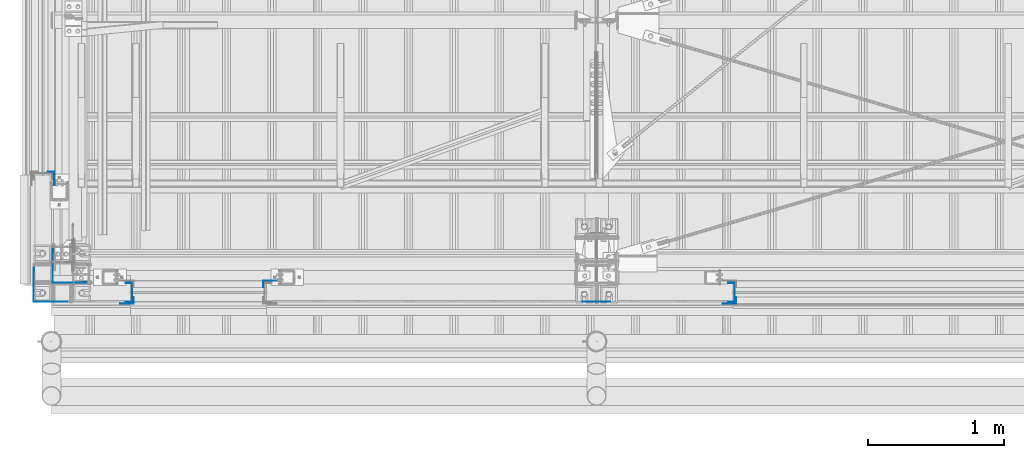
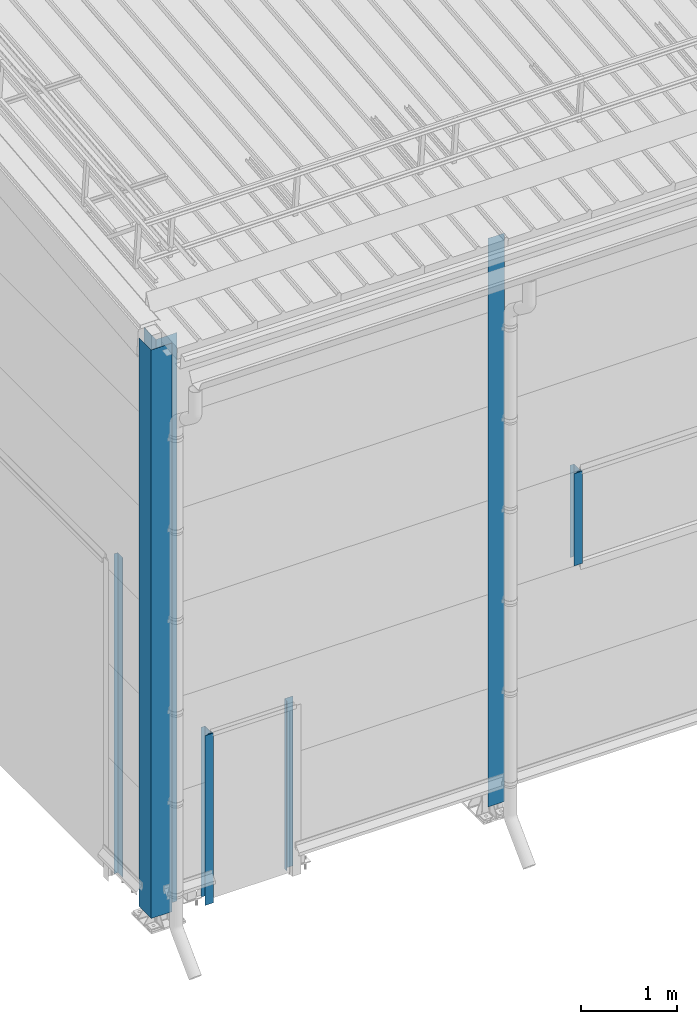
# One storey, part 1 of 709: 9 columns, 9 elements without a shape of their own.
"""IFC4 building model written with IfcOpenShell, lengths in millimetres."""

from ifc_helpers import new_model, si_unit, direction, frame, origin_with_axes, place, context, subcontext, project, spatial, line, indexed_curve, outline, extrude, material, element, aggregate, save


model = new_model("IFC4")

# Units and contexts
model_context = context("Model", 3, precision=0.2, world=origin_with_axes(), true_north=direction((0.0, 1.0)))
body_context = subcontext(model_context, "Body", "Model", "MODEL_VIEW")
ifc_project = project(units=[si_unit("LENGTHUNIT", "METRE", prefix="MILLI"), si_unit("AREAUNIT", "SQUARE_METRE"), si_unit("VOLUMEUNIT", "CUBIC_METRE"), si_unit("MASSUNIT", "GRAM", prefix="KILO"), si_unit("TIMEUNIT", "SECOND"), si_unit("PLANEANGLEUNIT", "RADIAN"), si_unit("SOLIDANGLEUNIT", "STERADIAN"), si_unit("THERMODYNAMICTEMPERATUREUNIT", "DEGREE_CELSIUS"), si_unit("LUMINOUSINTENSITYUNIT", "LUMEN")], contexts=[model_context])

# Site, building, storey
site_placement = place(None, origin_with_axes())
site = spatial("IfcSite", under=ifc_project, at=site_placement, CompositionType="ELEMENT")
building_placement = place(site_placement, origin_with_axes())
building = spatial("IfcBuilding", under=site, at=building_placement, Name="Undefined", CompositionType="ELEMENT")
storey_placement = place(building_placement, origin_with_axes())
storey = spatial("IfcBuildingStorey", under=building, at=storey_placement, Name="Undefined", CompositionType="ELEMENT", Elevation=0.0)

# Assembly, column
assembly_1_placement = place(storey_placement, frame((1555.0, 1.0, -50.0), z_axis=(0.0, 1.0, 0.0), x_axis=(0.0, 0.0, 1.0)))
assembly_1 = element("IfcElementAssembly", 1, at=assembly_1_placement, inside=storey)
ifc_material = material(Name="Steel_Undefined", Category="STEEL")
column_1_placement = place(assembly_1_placement, origin_with_axes())
column_1 = element("IfcColumn", 2, at=column_1_placement, material=ifc_material, context=body_context, shape_type="SolidModel", body=[
    extrude(outline(indexed_curve([(-25.0, -1.0), (25.0, -1.0), (25.0, 99.0), (23.0, 99.0), (23.0, 1.0), (-25.0, 1.0)], segments=[line(1, 2, 3, 4, 5, 6, 1)])), frame((0.0, 0.0, 0.0), z_axis=(-1.0, 0.0, 0.0), x_axis=(0.0, 0.0, 1.0)), (0.0, 0.0, -1.0), 2150.0),
])
aggregate(assembly_1, [column_1])

assembly_2_placement = place(storey_placement, frame((570.0, -60.0, -50.0), z_axis=(0.0, 1.0, 0.0), x_axis=(0.0, 0.0, 1.0)))
assembly_2 = element("IfcElementAssembly", 3, at=assembly_2_placement, inside=storey)
column_2_placement = place(assembly_2_placement, origin_with_axes())
column_2 = element("IfcColumn", 4, at=column_2_placement, material=ifc_material, context=body_context, shape_type="SolidModel", body=[
    extrude(outline(indexed_curve([(-70.0, -25.0), (-68.0, -25.0), (-68.0, 23.0), (68.0, 23.0), (68.0, -25.0), (70.0, -25.0), (70.0, 25.0), (-70.0, 25.0)], segments=[line(1, 2, 3, 4, 5, 6, 7, 8, 1)])), frame((0.0, 0.0, 0.0), z_axis=(-1.0, 0.0, 0.0), x_axis=(0.0, 0.0, 1.0)), (0.0, 0.0, -1.0), 2150.0),
])
aggregate(assembly_2, [column_2])

assembly_3_placement = place(storey_placement, frame((605.0, -119.0, -50.0), z_axis=(0.0, -1.0, 0.0), x_axis=(0.0, 0.0, 1.0)))
assembly_3 = element("IfcElementAssembly", 5, at=assembly_3_placement, inside=storey)
column_3_placement = place(assembly_3_placement, origin_with_axes())
column_3 = element("IfcColumn", 6, at=column_3_placement, material=ifc_material, context=body_context, shape_type="SolidModel", body=[
    extrude(outline(indexed_curve([(-25.0, -1.0), (25.0, -1.0), (25.0, 99.0), (23.0, 99.0), (23.0, 1.0), (-25.0, 1.0)], segments=[line(1, 2, 3, 4, 5, 6, 1)])), frame((0.0, 0.0, 0.0), z_axis=(-1.0, 0.0, 0.0), x_axis=(0.0, 0.0, 1.0)), (0.0, 0.0, -1.0), 2150.0),
])
aggregate(assembly_3, [column_3])

assembly_4_placement = place(storey_placement, frame((4990.0, -60.0, 2700.0), z_axis=(0.0, 1.0, 0.0), x_axis=(0.0, 0.0, 1.0)))
assembly_4 = element("IfcElementAssembly", 7, at=assembly_4_placement, inside=storey)
column_4_placement = place(assembly_4_placement, origin_with_axes())
column_4 = element("IfcColumn", 8, at=column_4_placement, material=ifc_material, context=body_context, shape_type="SolidModel", body=[
    extrude(outline(indexed_curve([(-70.0, -25.0), (-68.0, -25.0), (-68.0, 23.0), (68.0, 23.0), (68.0, -25.0), (70.0, -25.0), (70.0, 25.0), (-70.0, 25.0)], segments=[line(1, 2, 3, 4, 5, 6, 7, 8, 1)])), frame((0.0, 0.0, 0.0), z_axis=(-1.0, 0.0, 0.0), x_axis=(0.0, 0.0, 1.0)), (0.0, 0.0, -1.0), 1170.0),
])
aggregate(assembly_4, [column_4])

assembly_5_placement = place(storey_placement, frame((5025.0, -119.0, 2700.0), z_axis=(0.0, -1.0, 0.0), x_axis=(0.0, 0.0, 1.0)))
assembly_5 = element("IfcElementAssembly", 9, at=assembly_5_placement, inside=storey)
column_5_placement = place(assembly_5_placement, origin_with_axes())
column_5 = element("IfcColumn", 10, at=column_5_placement, material=ifc_material, context=body_context, shape_type="SolidModel", body=[
    extrude(outline(indexed_curve([(-25.0, -1.0), (25.0, -1.0), (25.0, 99.0), (23.0, 99.0), (23.0, 1.0), (-25.0, 1.0)], segments=[line(1, 2, 3, 4, 5, 6, 1)])), frame((0.0, 0.0, 0.0), z_axis=(-1.0, 0.0, 0.0), x_axis=(0.0, 0.0, 1.0)), (0.0, 0.0, -1.0), 1170.0),
])
aggregate(assembly_5, [column_5])

assembly_6_placement = place(storey_placement, frame((-130.0, -130.0, 0.0), z_axis=(0.0, 1.0, 0.0), x_axis=(0.0, 0.0, 1.0)))
assembly_6 = element("IfcElementAssembly", 11, at=assembly_6_placement, inside=storey)
column_6_placement = place(assembly_6_placement, origin_with_axes())
column_6 = element("IfcColumn", 12, at=column_6_placement, material=ifc_material, context=body_context, shape_type="SolidModel", body=[
    extrude(outline(indexed_curve([(0.0, 0.0), (250.0, 0.0), (250.0, 3.0), (220.0, 3.0), (220.0, 2.0), (249.0, 2.0), (249.0, 1.0), (1.0, 1.0), (1.0, 249.0), (2.0, 249.0), (2.0, 220.0), (3.0, 220.0), (3.0, 250.0), (0.0, 250.0)], segments=[line(1, 2, 3, 4, 5, 6, 7, 8, 9, 10, 11, 12, 13, 14, 1)])), frame((0.0, 0.0, 0.0), z_axis=(-1.0, 0.0, 0.0), x_axis=(0.0, 0.0, 1.0)), (0.0, 0.0, -1.0), 7196.92297),
])
aggregate(assembly_6, [column_6])

assembly_7_placement = place(storey_placement, frame((10.0, 10.0, 0.0), z_axis=(0.0, 1.0, 0.0), x_axis=(0.0, 0.0, 1.0)))
assembly_7 = element("IfcElementAssembly", 13, at=assembly_7_placement, inside=storey)
column_7_placement = place(assembly_7_placement, origin_with_axes())
column_7 = element("IfcColumn", 14, at=column_7_placement, material=ifc_material, context=body_context, shape_type="SolidModel", body=[
    extrude(outline(indexed_curve([(0.0, 0.0), (250.0, 0.0), (250.0, 3.0), (220.0, 3.0), (220.0, 2.0), (249.0, 2.0), (249.0, 1.0), (1.0, 1.0), (1.0, 249.0), (2.0, 249.0), (2.0, 220.0), (3.0, 220.0), (3.0, 250.0), (0.0, 250.0)], segments=[line(1, 2, 3, 4, 5, 6, 7, 8, 9, 10, 11, 12, 13, 14, 1)])), frame((0.0, 0.0, 0.0), z_axis=(-1.0, 0.0, 0.0), x_axis=(0.0, 0.0, 1.0)), (0.0, 0.0, -1.0), 7196.92297),
])
aggregate(assembly_7, [column_7])

assembly_8_placement = place(storey_placement, frame((4000.0, -130.0, 0.0), z_axis=(0.0, 1.0, 0.0), x_axis=(0.0, 0.0, 1.0)))
assembly_8 = element("IfcElementAssembly", 15, at=assembly_8_placement, inside=storey)
column_8_placement = place(assembly_8_placement, origin_with_axes())
column_8 = element("IfcColumn", 16, at=column_8_placement, material=ifc_material, context=body_context, shape_type="SolidModel", body=[
    extrude(outline(indexed_curve([(-0.375, -100.0), (1.245, -100.0), (1.245, -50.0), (0.495, -50.0), (0.495, -99.25), (0.375, -99.25), (0.375, 99.25), (0.495, 99.25), (0.495, 50.0), (1.245, 50.0), (1.245, 100.0), (-0.375, 100.0)], segments=[line(1, 2, 3, 4, 5, 6, 7, 8, 9, 10, 11, 12, 1)])), frame((0.0, 0.0, 0.0), z_axis=(-1.0, 0.0, 0.0), x_axis=(0.0, 0.0, 1.0)), (0.0, 0.0, -1.0), 7196.92297),
])
aggregate(assembly_8, [column_8])

assembly_9_placement = place(storey_placement, frame((-1.0, 825.0, -50.0), z_axis=(1.0, 0.0, 0.0), x_axis=(0.0, 0.0, 1.0)))
assembly_9 = element("IfcElementAssembly", 17, at=assembly_9_placement, inside=storey)
column_9_placement = place(assembly_9_placement, origin_with_axes())
column_9 = element("IfcColumn", 18, at=column_9_placement, material=ifc_material, context=body_context, shape_type="SolidModel", body=[
    extrude(outline(indexed_curve([(-25.0, -1.0), (25.0, -1.0), (25.0, 99.0), (23.0, 99.0), (23.0, 1.0), (-25.0, 1.0)], segments=[line(1, 2, 3, 4, 5, 6, 1)])), frame((0.0, 0.0, 0.0), z_axis=(-1.0, 0.0, 0.0), x_axis=(0.0, 0.0, 1.0)), (0.0, 0.0, -1.0), 4050.0),
])
aggregate(assembly_9, [column_9])

save(model, "model.ifc")
